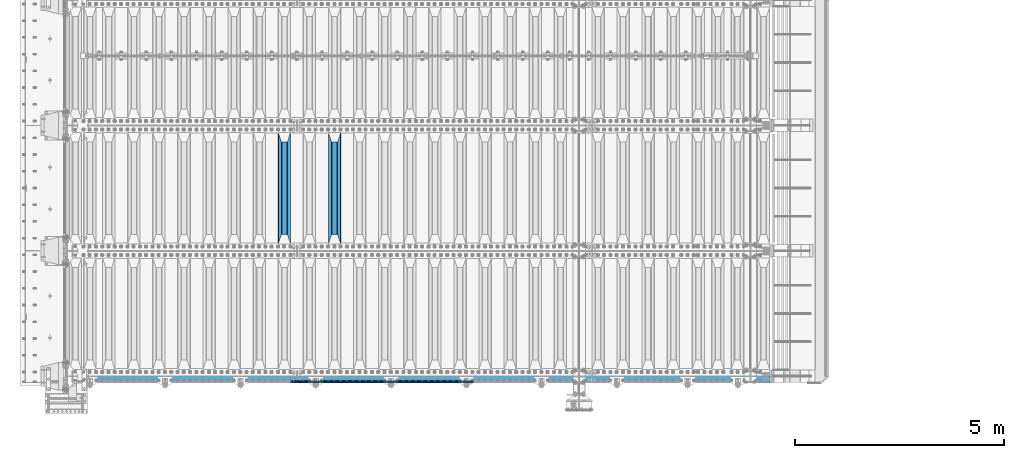
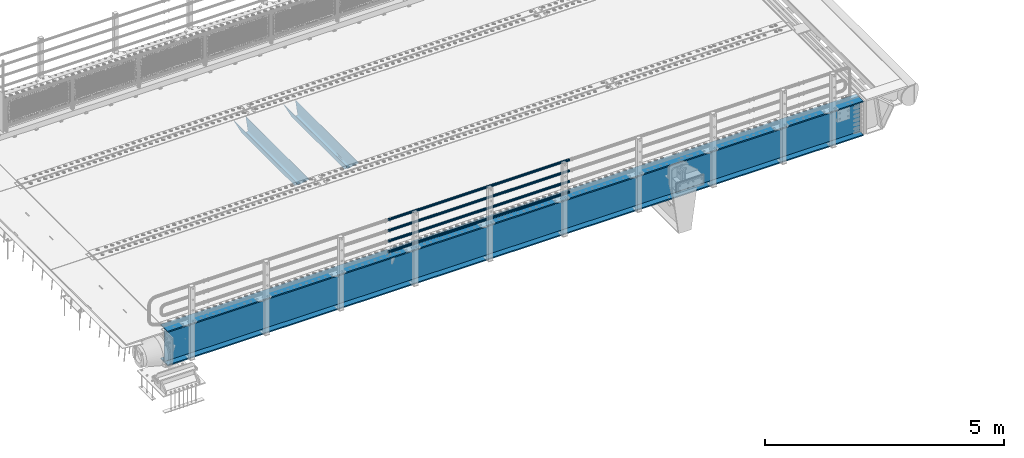
# One storey, part 112 of 247: 7 beams.
"""IFC2X3 building model written with IfcOpenShell, lengths in millimetres."""

import ifcopenshell
import ifcopenshell.guid

model = None  # the IFC model being written
_history = None  # IfcOwnerHistory: only IFC2X3 demands one
_inside = {}  # id of a spatial element -> (the spatial element, [elements in it])
_under = {}  # id of a project, library or spatial element -> (it, [spatial elements below it])
_declared = {}  # id of a project -> (the project, [libraries it declares])
_typed = {}  # id of a type object -> (the type object, [elements of that type])
_made_of = {}  # id of a material, layer set ... -> (it, [elements and type objects made of it])


def new_model(schema):
    """Start an empty IFC model of exactly this schema.

    Asked for "IFC4X3", IfcOpenShell would pick the latest addendum, in which some entities
    have other attributes; the version numbers below select the first issue.
    IFC2X3 requires an IfcOwnerHistory on every rooted entity: one is made here for all.
    """
    global model, _history
    if schema == "IFC4X3":
        model = ifcopenshell.file(schema_version=(4, 3, 0, 0))
    else:
        model = ifcopenshell.file(schema=schema)
    _inside.clear()
    _under.clear()
    _declared.clear()
    _typed.clear()
    _made_of.clear()
    _history = None
    if model.schema == "IFC2X3":
        org = make("IfcOrganization", Name="unknown")
        user = make(
            "IfcPersonAndOrganization",
            ThePerson=make("IfcPerson", FamilyName="unknown"),
            TheOrganization=org,
        )
        app = make(
            "IfcApplication",
            ApplicationDeveloper=org,
            Version="unknown",
            ApplicationFullName="unknown",
            ApplicationIdentifier="unknown",
        )
        _history = make(
            "IfcOwnerHistory",
            OwningUser=user,
            OwningApplication=app,
            ChangeAction="ADDED",
            CreationDate=0,
        )
    return model


def make(cls, **values):
    """One entity of the class cls with the attributes given. An attribute that is None is left unset."""
    return model.create_entity(
        cls, **{name: value for name, value in values.items() if value is not None}
    )


def rooted(cls, **values):
    """An entity with a GlobalId (a new one), such as an element, a storey or a relation."""
    return make(cls, GlobalId=ifcopenshell.guid.new(), OwnerHistory=_history, **values)


def si_unit(unit_type, name, prefix=None):
    """IfcSIUnit, for example si_unit("LENGTHUNIT", "METRE", prefix="MILLI")."""
    return make("IfcSIUnit", UnitType=unit_type, Prefix=prefix, Name=name)


def assignment(units):
    """IfcUnitAssignment: the units of a project."""
    return None if units is None else make("IfcUnitAssignment", Units=units)


def point(xyz):
    """IfcCartesianPoint."""
    return None if xyz is None else make("IfcCartesianPoint", Coordinates=xyz)


def direction(xyz):
    """IfcDirection."""
    return None if xyz is None else make("IfcDirection", DirectionRatios=xyz)


def frame(location, z_axis=None, x_axis=None):
    """IfcAxis2Placement3D, a coordinate frame: its origin and axes. An axis left out is left unset."""
    return make(
        "IfcAxis2Placement3D",
        Location=point(location),
        Axis=direction(z_axis),
        RefDirection=direction(x_axis),
    )


def origin_with_axes():
    """The frame at (0, 0, 0) with the z axis (0, 0, 1) and the x axis (1, 0, 0) written out."""
    return frame((0.0, 0.0, 0.0), z_axis=(0.0, 0.0, 1.0), x_axis=(1.0, 0.0, 0.0))


def place(relative_to, where):
    """IfcLocalPlacement: puts the frame where relative to a parent placement (None: the world)."""
    return make(
        "IfcLocalPlacement", PlacementRelTo=relative_to, RelativePlacement=where
    )


def context(
    kind, dimensions, precision=None, world=None, true_north=None, identifier=None
):
    """IfcGeometricRepresentationContext, for example the 3D "Model" context."""
    return make(
        "IfcGeometricRepresentationContext",
        ContextIdentifier=identifier,
        ContextType=kind,
        CoordinateSpaceDimension=dimensions,
        Precision=precision,
        WorldCoordinateSystem=world,
        TrueNorth=true_north,
    )


def subcontext(parent, identifier, kind, view, scale=None):
    """IfcGeometricRepresentationSubContext, for example "Body" below "Model"."""
    return make(
        "IfcGeometricRepresentationSubContext",
        ContextIdentifier=identifier,
        ContextType=kind,
        ParentContext=parent,
        TargetScale=scale,
        TargetView=view,
    )


def project(units=None, contexts=None):
    """IfcProject with its units and contexts."""
    return rooted(
        "IfcProject",
        Name="project",
        RepresentationContexts=contexts,
        UnitsInContext=assignment(units),
    )


def spatial(cls, under=None, at=None, **own):
    """A site, building, storey or space (cls), placed at a placement, below another one or the project."""
    s = rooted(cls, ObjectPlacement=at, **own)
    if under is not None:
        _under.setdefault(under.id(), (under, []))[1].append(s)
    return s


def faces_of(points, faces, orient=None, outer=None):
    """IfcFace entities. A face is a list of loops; a loop is a list of indices into points, from 0.

    orient and outer hold one flag for each loop. By default every Orientation is true, the
    first loop of a face is its IfcFaceOuterBound and the others are IfcFaceBound.
    """
    made = []
    for i, loops in enumerate(faces):
        bounds = []
        for j, loop in enumerate(loops):
            is_outer = j == 0 if outer is None else outer[i][j]
            bounds.append(
                make(
                    "IfcFaceOuterBound" if is_outer else "IfcFaceBound",
                    Bound=make("IfcPolyLoop", Polygon=[points[k] for k in loop]),
                    Orientation=True if orient is None else orient[i][j],
                )
            )
        made.append(make("IfcFace", Bounds=bounds))
    return made


def faceted_brep(points, faces, orient=None, outer=None, voids=None):
    """IfcFacetedBrep: a solid bounded by flat faces; with voids (closed shells), ...WithVoids."""
    shared = [point(p) for p in points]
    hull = make("IfcClosedShell", CfsFaces=faces_of(shared, faces, orient, outer))
    if voids is None:
        return make("IfcFacetedBrep", Outer=hull)
    return make(
        "IfcFacetedBrepWithVoids",
        Outer=hull,
        Voids=[
            make(cls, CfsFaces=faces_of(shared, fs, o, b)) for cls, fs, o, b in voids
        ],
    )


def shape(context_of_items, identifier, shape_type, items):
    """IfcShapeRepresentation: the items that make up one representation, for example the "Body"."""
    return make(
        "IfcShapeRepresentation",
        ContextOfItems=context_of_items,
        RepresentationIdentifier=identifier,
        RepresentationType=shape_type,
        Items=items,
    )


def material(Name=None, Category=None):
    """IfcMaterial."""
    return make("IfcMaterial", Name=Name, Category=Category)


def made_of(thing, what):
    """Note that an element or type object is made of a material, layer set ...; save() writes the relation."""
    if what is not None:
        _made_of.setdefault(what.id(), (what, []))[1].append(thing)
    return thing


def type_object(cls, material=None, **own):
    """A type object (cls), such as IfcWallType, which elements share."""
    return made_of(rooted(cls, **own), material)


def element(
    cls,
    number,
    at=None,
    inside=None,
    cuts=None,
    type_object=None,
    material=None,
    context=None,
    identifier="Body",
    shape_type=None,
    held_by="IfcProductDefinitionShape",
    body=None,
    shapes=None,
    **own,
):
    """One element of the class cls, such as IfcWall. Its Tag is "e" and its number.

    at: its placement. inside: the storey or other place that contains it. cuts: it is an
    opening in that element (IfcRelVoidsElement). A single representation is given by context,
    identifier, shape_type and body (its items); several are given by shapes. held_by: the class
    of the entity that holds the representations. save() writes the other relations.
    """
    e = rooted(cls, Tag="e%d" % number, ObjectPlacement=at, **own)
    if body is not None:
        shapes = [shape(context, identifier, shape_type, body)]
    if shapes is not None:
        e.Representation = make(held_by, Representations=shapes)
    if inside is not None:
        _inside.setdefault(inside.id(), (inside, []))[1].append(e)
    if cuts is not None:
        rooted(
            "IfcRelVoidsElement", RelatingBuildingElement=cuts, RelatedOpeningElement=e
        )
    if type_object is not None:
        _typed.setdefault(type_object.id(), (type_object, []))[1].append(e)
    return made_of(e, material)


def aggregate(whole, parts):
    """IfcRelAggregates: a whole, such as a stair, and the parts it consists of."""
    return rooted("IfcRelAggregates", RelatingObject=whole, RelatedObjects=parts)


def save(model, path):
    """Write the relations noted so far, then the file.

    IfcRelAggregates (storeys below a building ...), IfcRelContainedInSpatialStructure (elements
    in a storey), IfcRelDefinesByType, IfcRelAssociatesMaterial and IfcRelDeclares: one each for
    every whole, place, type object, material and project.
    """
    for whole, parts in _under.values():
        aggregate(whole, parts)
    for where, things in _inside.values():
        rooted(
            "IfcRelContainedInSpatialStructure",
            RelatedElements=things,
            RelatingStructure=where,
        )
    for kind, things in _typed.values():
        rooted("IfcRelDefinesByType", RelatedObjects=things, RelatingType=kind)
    for what, things in _made_of.values():
        rooted("IfcRelAssociatesMaterial", RelatedObjects=things, RelatingMaterial=what)
    for by, libraries in _declared.values():
        rooted("IfcRelDeclares", RelatingContext=by, RelatedDefinitions=libraries)
    model.write(path)


model = new_model("IFC2X3")

# Units and contexts
model_context = context("Model", 3, precision=1e-05, world=origin_with_axes())
body_context = subcontext(model_context, "Body", "Model", "MODEL_VIEW")
ifc_project = project(units=[si_unit("LENGTHUNIT", "METRE", prefix="MILLI"), si_unit("AREAUNIT", "SQUARE_METRE"), si_unit("VOLUMEUNIT", "CUBIC_METRE"), si_unit("MASSUNIT", "GRAM", prefix="KILO"), si_unit("TIMEUNIT", "SECOND"), si_unit("PLANEANGLEUNIT", "RADIAN"), si_unit("SOLIDANGLEUNIT", "STERADIAN"), si_unit("THERMODYNAMICTEMPERATUREUNIT", "DEGREE_CELSIUS"), si_unit("LUMINOUSINTENSITYUNIT", "LUMEN")], contexts=[model_context])

# Site, building, storey
site_placement = place(None, origin_with_axes())
site = spatial("IfcSite", under=ifc_project, at=site_placement, CompositionType="ELEMENT")
building_placement = place(site_placement, origin_with_axes())
building = spatial("IfcBuilding", under=site, at=building_placement, Name="Standard", CompositionType="ELEMENT")
storey_placement = place(building_placement, origin_with_axes())
storey = spatial("IfcBuildingStorey", under=building, at=storey_placement, Name="Undefined", CompositionType="ELEMENT", Elevation=0.0)

# Beams
ifc_material_1 = material(Name="STEEL/S355N")
beam_type_1 = type_object("IfcBeamType", PredefinedType="NOTDEFINED")
beam_1_placement = place(storey_placement, frame((6400.0, 3175.0, -115.0), z_axis=(0.0, 0.0, 1.0), x_axis=(0.0, 1.0, 0.0)))
element("IfcBeam", 1, at=beam_1_placement, inside=storey, type_object=beam_type_1, material=ifc_material_1, context=body_context, shape_type="Brep", body=[
    faceted_brep([(0.0, 150.0, 115.0), (0.0, 143.689999999999, 115.0), (2650.00000000297, 143.689999999999, 115.0), (2650.00000000297, 150.0, 115.0), (2650.00000000297, 142.059565218402, 110.0000000031), (2650.00000000297, 148.369565218403, 110.0000000031), (2441.90079219208, -80.1103600731112, -98.0992078077845), (2437.7588105432, -77.5672621345584, -102.241189456673), (2434.06523489746, -74.4080125315522, -105.934765102404), (2430.91086095089, -70.710272125576, -109.089139048974), (2428.37322971128, -66.5649389910068, -111.626770288588), (2426.51472138054, -62.0739139532889, -113.485278619323), (2425.38102192091, -57.3475956567672, -114.618978078955), (2424.99999999987, -52.5021667386536, -115.0), (2424.99999999987, 52.5021667386536, -115.0), (2425.38102192091, 57.3475956567672, -114.618978078955), (2426.51472138054, 62.0739139532889, -113.485278619323), (2428.37322971128, 66.5649389910068, -111.626770288588), (2430.91086095089, 70.710272125576, -109.089139048974), (2434.06523489746, 74.4080125315522, -105.934765102404), (2437.7588105432, 77.5672621345584, -102.241189456673), (2441.90079219208, 80.1103600731112, -98.0992078077846), (2446.38936140511, 81.9747917625791, -93.6106385947584), (2448.24948500409, 76.2713538057251, -91.7505149957729), (2444.62967112262, 74.76777986261, -95.3703288772456), (2441.28936334126, 72.7168944282894, -98.710636658607), (2438.31067330438, 70.1691124903846, -101.689326695487), (2435.76682334747, 67.1870637758839, -104.233176652398), (2433.72034654133, 63.8440531834895, -106.279653458539), (2432.22154950041, 60.222258798236, -107.778450499454), (2431.30727574265, 56.4107117849089, -108.692724257221), (2430.99999999987, 52.5031078186876, -109.0), (2430.99999999987, -52.5031078186876, -109.0), (2431.30727574265, -56.4107117849089, -108.692724257221), (2432.22154950041, -60.222258798236, -107.778450499454), (2433.72034654133, -63.8440531834895, -106.279653458539), (2435.76682334747, -67.1870637758839, -104.233176652398), (2438.31067330438, -70.1691124903846, -101.689326695487), (2441.28936334126, -72.7168944282894, -98.7106366586071), (2444.62967112262, -74.76777986261, -95.3703288772457), (2448.24948500409, -76.2713538057251, -91.7505149957729), (2650.00000000297, -142.059565218402, 110.0000000031), (2650.00000000297, -148.369565218403, 110.0000000031), (2446.38936140511, -81.9747917625791, -93.6106385947584), (2650.00000000297, -143.689999999999, 115.0), (2650.00000000297, -150.0, 115.0), (0.0, -143.689999999999, 115.0), (0.0, -150.0, 115.0), (0.0, -148.369565218261, 110.000000002663), (203.610638597422, -81.9747917625791, -93.6106385947584), (208.099207810448, -80.1103600731112, -98.0992078077845), (212.241189459336, -77.5672621345584, -102.241189456673), (215.934765105068, -74.4080125315522, -105.934765102404), (219.089139051637, -70.710272125576, -109.089139048974), (221.626770291251, -66.5649389910068, -111.626770288588), (223.485278621985, -62.0739139532889, -113.485278619323), (224.618978081617, -57.3475956567672, -114.618978078955), (225.000000002663, -52.5021667386536, -115.0), (225.000000002663, 52.5021667386536, -115.0), (224.618978081617, 57.3475956567672, -114.618978078955), (223.485278621985, 62.0739139532889, -113.485278619323), (221.626770291251, 66.5649389910068, -111.626770288588), (219.089139051637, 70.710272125576, -109.089139048974), (215.934765105068, 74.4080125315522, -105.934765102404), (212.241189459336, 77.5672621345584, -102.241189456673), (208.099207810448, 80.1103600731112, -98.0992078077846), (203.610638597422, 81.9747917625791, -93.6106385947584), (0.0, 148.369565218261, 110.000000002663), (0.0, 142.05956521826, 110.000000002663), (201.750514998436, 76.2713538057251, -91.7505149957729), (205.370328879908, 74.76777986261, -95.3703288772456), (208.710636661271, 72.7168944282894, -98.710636658607), (211.68932669815, 70.1691124903846, -101.689326695487), (214.233176655061, 67.1870637758839, -104.233176652398), (216.279653461202, 63.8440531834895, -106.279653458539), (217.778450502117, 60.222258798236, -107.778450499454), (218.692724259885, 56.4107117849089, -108.692724257221), (219.000000002663, 52.5031078186876, -109.0), (219.000000002663, -52.5031078186876, -109.0), (218.692724259885, -56.4107117849089, -108.692724257221), (217.778450502117, -60.222258798236, -107.778450499454), (216.279653461202, -63.8440531834895, -106.279653458539), (214.233176655061, -67.1870637758839, -104.233176652398), (211.68932669815, -70.1691124903846, -101.689326695487), (208.710636661271, -72.7168944282894, -98.7106366586071), (205.370328879908, -74.76777986261, -95.3703288772457), (201.750514998436, -76.2713538057251, -91.7505149957729), (0.0, -142.05956521826, 110.000000002663)], [[[0, 1, 2, 3]], [[3, 2, 4, 5]], [[6, 7, 8, 9, 10, 11, 12, 13, 14, 15, 16, 17, 18, 19, 20, 21, 22, 5, 4, 23, 24, 25, 26, 27, 28, 29, 30, 31, 32, 33, 34, 35, 36, 37, 38, 39, 40, 41, 42, 43]], [[44, 45, 42, 41]], [[46, 47, 45, 44]], [[43, 42, 45, 47, 48, 49]], [[6, 43, 49, 50]], [[7, 6, 50, 51]], [[8, 7, 51, 52]], [[9, 8, 52, 53]], [[10, 9, 53, 54]], [[11, 10, 54, 55]], [[12, 11, 55, 56]], [[13, 12, 56, 57]], [[14, 13, 57, 58]], [[15, 14, 58, 59]], [[16, 15, 59, 60]], [[17, 16, 60, 61]], [[18, 17, 61, 62]], [[19, 18, 62, 63]], [[20, 19, 63, 64]], [[21, 20, 64, 65]], [[22, 21, 65, 66]], [[0, 3, 5, 22, 66, 67]], [[1, 0, 67, 68]], [[23, 4, 2, 1, 68, 69]], [[24, 23, 69, 70]], [[25, 24, 70, 71]], [[26, 25, 71, 72]], [[27, 26, 72, 73]], [[28, 27, 73, 74]], [[29, 28, 74, 75]], [[30, 29, 75, 76]], [[31, 30, 76, 77]], [[32, 31, 77, 78]], [[33, 32, 78, 79]], [[34, 33, 79, 80]], [[35, 34, 80, 81]], [[36, 35, 81, 82]], [[37, 36, 82, 83]], [[38, 37, 83, 84]], [[39, 38, 84, 85]], [[40, 39, 85, 86]], [[46, 44, 41, 40, 86, 87]], [[47, 46, 87, 48]], [[86, 85, 84, 83, 82, 81, 80, 79, 78, 77, 76, 75, 74, 73, 72, 71, 70, 69, 68, 67, 66, 65, 64, 63, 62, 61, 60, 59, 58, 57, 56, 55, 54, 53, 52, 51, 50, 49, 48, 87]]]),
])
beam_2_placement = place(storey_placement, frame((5200.0, 3175.0, -115.0), z_axis=(0.0, 0.0, 1.0), x_axis=(0.0, 1.0, 0.0)))
element("IfcBeam", 2, at=beam_2_placement, inside=storey, type_object=beam_type_1, material=ifc_material_1, context=body_context, shape_type="Brep", body=[
    faceted_brep([(0.0, 150.0, 115.0), (0.0, 143.689999999999, 115.0), (2650.00000000297, 143.689999999999, 115.0), (2650.00000000297, 150.0, 115.0), (2650.00000000297, 142.059565218402, 110.0000000031), (2650.00000000297, 148.369565218403, 110.0000000031), (2441.90079219208, -80.1103600731112, -98.0992078077845), (2437.7588105432, -77.5672621345584, -102.241189456673), (2434.06523489746, -74.4080125315522, -105.934765102404), (2430.91086095089, -70.710272125576, -109.089139048974), (2428.37322971128, -66.5649389910068, -111.626770288588), (2426.51472138054, -62.0739139532889, -113.485278619323), (2425.38102192091, -57.3475956567672, -114.618978078955), (2424.99999999987, -52.5021667386536, -115.0), (2424.99999999987, 52.5021667386536, -115.0), (2425.38102192091, 57.3475956567672, -114.618978078955), (2426.51472138054, 62.0739139532889, -113.485278619323), (2428.37322971128, 66.5649389910068, -111.626770288588), (2430.91086095089, 70.710272125576, -109.089139048974), (2434.06523489746, 74.4080125315522, -105.934765102404), (2437.7588105432, 77.5672621345584, -102.241189456673), (2441.90079219208, 80.1103600731112, -98.0992078077846), (2446.38936140511, 81.9747917625791, -93.6106385947584), (2448.24948500409, 76.2713538057251, -91.7505149957729), (2444.62967112262, 74.76777986261, -95.3703288772456), (2441.28936334126, 72.7168944282894, -98.710636658607), (2438.31067330438, 70.1691124903846, -101.689326695487), (2435.76682334747, 67.1870637758839, -104.233176652398), (2433.72034654133, 63.8440531834895, -106.279653458539), (2432.22154950041, 60.222258798236, -107.778450499454), (2431.30727574265, 56.4107117849089, -108.692724257221), (2430.99999999987, 52.5031078186876, -109.0), (2430.99999999987, -52.5031078186876, -109.0), (2431.30727574265, -56.4107117849089, -108.692724257221), (2432.22154950041, -60.222258798236, -107.778450499454), (2433.72034654133, -63.8440531834895, -106.279653458539), (2435.76682334747, -67.1870637758839, -104.233176652398), (2438.31067330438, -70.1691124903846, -101.689326695487), (2441.28936334126, -72.7168944282894, -98.7106366586071), (2444.62967112262, -74.76777986261, -95.3703288772457), (2448.24948500409, -76.2713538057251, -91.7505149957729), (2650.00000000297, -142.059565218402, 110.0000000031), (2650.00000000297, -148.369565218403, 110.0000000031), (2446.38936140511, -81.9747917625791, -93.6106385947584), (2650.00000000297, -143.689999999999, 115.0), (2650.00000000297, -150.0, 115.0), (0.0, -143.689999999999, 115.0), (0.0, -150.0, 115.0), (0.0, -148.369565218261, 110.000000002663), (203.610638597422, -81.9747917625791, -93.6106385947584), (208.099207810448, -80.1103600731112, -98.0992078077845), (212.241189459336, -77.5672621345584, -102.241189456673), (215.934765105068, -74.4080125315522, -105.934765102404), (219.089139051637, -70.710272125576, -109.089139048974), (221.626770291251, -66.5649389910068, -111.626770288588), (223.485278621985, -62.0739139532889, -113.485278619323), (224.618978081617, -57.3475956567672, -114.618978078955), (225.000000002663, -52.5021667386536, -115.0), (225.000000002663, 52.5021667386536, -115.0), (224.618978081617, 57.3475956567672, -114.618978078955), (223.485278621985, 62.0739139532889, -113.485278619323), (221.626770291251, 66.5649389910068, -111.626770288588), (219.089139051637, 70.710272125576, -109.089139048974), (215.934765105068, 74.4080125315522, -105.934765102404), (212.241189459336, 77.5672621345584, -102.241189456673), (208.099207810448, 80.1103600731112, -98.0992078077846), (203.610638597422, 81.9747917625791, -93.6106385947584), (0.0, 148.369565218261, 110.000000002663), (0.0, 142.05956521826, 110.000000002663), (201.750514998436, 76.2713538057251, -91.7505149957729), (205.370328879908, 74.76777986261, -95.3703288772456), (208.710636661271, 72.7168944282894, -98.710636658607), (211.68932669815, 70.1691124903846, -101.689326695487), (214.233176655061, 67.1870637758839, -104.233176652398), (216.279653461202, 63.8440531834895, -106.279653458539), (217.778450502117, 60.222258798236, -107.778450499454), (218.692724259885, 56.4107117849089, -108.692724257221), (219.000000002663, 52.5031078186876, -109.0), (219.000000002663, -52.5031078186876, -109.0), (218.692724259885, -56.4107117849089, -108.692724257221), (217.778450502117, -60.222258798236, -107.778450499454), (216.279653461202, -63.8440531834895, -106.279653458539), (214.233176655061, -67.1870637758839, -104.233176652398), (211.68932669815, -70.1691124903846, -101.689326695487), (208.710636661271, -72.7168944282894, -98.7106366586071), (205.370328879908, -74.76777986261, -95.3703288772457), (201.750514998436, -76.2713538057251, -91.7505149957729), (0.0, -142.05956521826, 110.000000002663)], [[[0, 1, 2, 3]], [[3, 2, 4, 5]], [[6, 7, 8, 9, 10, 11, 12, 13, 14, 15, 16, 17, 18, 19, 20, 21, 22, 5, 4, 23, 24, 25, 26, 27, 28, 29, 30, 31, 32, 33, 34, 35, 36, 37, 38, 39, 40, 41, 42, 43]], [[44, 45, 42, 41]], [[46, 47, 45, 44]], [[43, 42, 45, 47, 48, 49]], [[6, 43, 49, 50]], [[7, 6, 50, 51]], [[8, 7, 51, 52]], [[9, 8, 52, 53]], [[10, 9, 53, 54]], [[11, 10, 54, 55]], [[12, 11, 55, 56]], [[13, 12, 56, 57]], [[14, 13, 57, 58]], [[15, 14, 58, 59]], [[16, 15, 59, 60]], [[17, 16, 60, 61]], [[18, 17, 61, 62]], [[19, 18, 62, 63]], [[20, 19, 63, 64]], [[21, 20, 64, 65]], [[22, 21, 65, 66]], [[0, 3, 5, 22, 66, 67]], [[1, 0, 67, 68]], [[23, 4, 2, 1, 68, 69]], [[24, 23, 69, 70]], [[25, 24, 70, 71]], [[26, 25, 71, 72]], [[27, 26, 72, 73]], [[28, 27, 73, 74]], [[29, 28, 74, 75]], [[30, 29, 75, 76]], [[31, 30, 76, 77]], [[32, 31, 77, 78]], [[33, 32, 78, 79]], [[34, 33, 79, 80]], [[35, 34, 80, 81]], [[36, 35, 81, 82]], [[37, 36, 82, 83]], [[38, 37, 83, 84]], [[39, 38, 84, 85]], [[40, 39, 85, 86]], [[46, 44, 41, 40, 86, 87]], [[47, 46, 87, 48]], [[86, 85, 84, 83, 82, 81, 80, 79, 78, 77, 76, 75, 74, 73, 72, 71, 70, 69, 68, 67, 66, 65, 64, 63, 62, 61, 60, 59, 58, 57, 56, 55, 54, 53, 52, 51, 50, 49, 48, 87]]]),
])
ifc_material_2 = material()
beam_type_2 = type_object("IfcBeamType", PredefinedType="NOTDEFINED")
beam_3_placement = place(storey_placement, frame((9727.99999999987, -129.849999999907, 149.849999999725), z_axis=(0.0, 0.0, -1.0), x_axis=(-1.0, 0.0, 0.0)))
element("IfcBeam", 3, at=beam_3_placement, inside=storey, type_object=beam_type_2, material=ifc_material_2, context=body_context, shape_type="Brep", body=[
    faceted_brep([(0.0, -26.5499999999993, 0.0), (0.0, -24.5290015881747, 10.1602451292931), (4384.00249699992, -24.5290015881747, 10.1602451292931), (4384.00249699992, -26.5499999999993, 0.0), (0.0, -18.7736850405036, 18.7736850405028), (4384.00249699992, -18.7736850405036, 18.7736850405028), (0.0, -10.1602451292929, 24.5290015881747), (4384.00249699992, -10.1602451292929, 24.5290015881747), (0.0, 0.0, 26.55), (4384.00249699992, 0.0, 26.55), (0.0, 10.1602451292929, 24.5290015881747), (4384.00249699992, 10.1602451292929, 24.5290015881747), (0.0, 18.7736850405036, 18.7736850405028), (4384.00249699992, 18.7736850405036, 18.7736850405028), (0.0, 24.5290015881747, 10.1602451292931), (4384.00249699992, 24.5290015881747, 10.1602451292931), (0.0, 26.5499999999993, 0.0), (4384.00249699992, 26.5499999999993, 0.0), (0.0, 24.5290015881747, -10.1602451292931), (4384.00249699992, 24.5290015881747, -10.1602451292931), (0.0, 18.7736850405036, -18.7736850405028), (4384.00249699992, 18.7736850405036, -18.7736850405028), (0.0, 10.1602451292929, -24.5290015881747), (4384.00249699992, 10.1602451292929, -24.5290015881747), (0.0, 0.0, -26.55), (4384.00249699992, 0.0, -26.55), (0.0, -10.1602451292929, -24.5290015881747), (4384.00249699992, -10.1602451292929, -24.5290015881747), (0.0, -18.7736850405036, -18.7736850405028), (4384.00249699992, -18.7736850405036, -18.7736850405028), (0.0, -24.5290015881747, -10.1602451292931), (4384.00249699992, -24.5290015881747, -10.1602451292931), (0.0, -30.1499999999996, 0.0), (0.0, -27.8549679052148, -11.5379054858076), (4384.00249699992, -27.8549679052157, -11.5379054858075), (4384.00249699992, -30.1499999999996, 0.0), (0.0, -21.3192694527743, -21.3192694527752), (4384.00249699992, -21.3192694527752, -21.3192694527744), (0.0, -11.5379054858076, -27.8549679052157), (4384.00249699992, -11.5379054858076, -27.8549679052153), (0.0, 0.0, -30.1499999999996), (4384.00249699992, 0.0, -30.15), (0.0, 11.5379054858076, -27.8549679052157), (4384.00249699992, 11.5379054858076, -27.8549679052153), (0.0, 21.3192694527743, -21.3192694527752), (4384.00249699992, 21.3192694527752, -21.3192694527744), (0.0, 27.8549679052157, -11.5379054858076), (4384.00249699992, 27.8549679052157, -11.5379054858074), (0.0, 30.1499999999996, 0.0), (4384.00249699992, 30.1499999999996, 0.0), (0.0, 27.8549679052157, 11.5379054858076), (4384.00249699992, 27.8549679052157, 11.5379054858075), (0.0, 21.3192694527743, 21.3192694527752), (4384.00249699992, 21.3192694527752, 21.3192694527744), (0.0, 11.5379054858076, 27.8549679052157), (4384.00249699992, 11.5379054858076, 27.8549679052153), (0.0, 0.0, 30.1499999999996), (4384.00249699992, 0.0, 30.15), (0.0, -11.5379054858076, 27.8549679052157), (4384.00249699992, -11.5379054858076, 27.8549679052153), (0.0, -21.3192694527743, 21.3192694527752), (4384.00249699992, -21.3192694527752, 21.3192694527744), (0.0, -27.8549679052157, 11.5379054858076), (4384.00249699992, -27.8549679052157, 11.5379054858075)], [[[0, 1, 2, 3]], [[1, 4, 5, 2]], [[4, 6, 7, 5]], [[6, 8, 9, 7]], [[8, 10, 11, 9]], [[10, 12, 13, 11]], [[12, 14, 15, 13]], [[14, 16, 17, 15]], [[16, 18, 19, 17]], [[18, 20, 21, 19]], [[20, 22, 23, 21]], [[22, 24, 25, 23]], [[24, 26, 27, 25]], [[26, 28, 29, 27]], [[28, 30, 31, 29]], [[30, 0, 3, 31]], [[32, 33, 34, 35]], [[33, 36, 37, 34]], [[36, 38, 39, 37]], [[38, 40, 41, 39]], [[40, 42, 43, 41]], [[42, 44, 45, 43]], [[44, 46, 47, 45]], [[46, 48, 49, 47]], [[48, 50, 51, 49]], [[50, 52, 53, 51]], [[52, 54, 55, 53]], [[54, 56, 57, 55]], [[56, 58, 59, 57]], [[58, 60, 61, 59]], [[60, 62, 63, 61]], [[62, 32, 35, 63]], [[37, 39, 41, 43, 45, 47, 49, 51, 53, 55, 57, 59, 61, 63, 35, 34], [5, 7, 9, 11, 13, 15, 17, 19, 21, 23, 25, 27, 29, 31, 3, 2]], [[62, 60, 58, 56, 54, 52, 50, 48, 46, 44, 42, 40, 38, 36, 33, 32], [30, 28, 26, 24, 22, 20, 18, 16, 14, 12, 10, 8, 6, 4, 1, 0]]]),
])
beam_4_placement = place(storey_placement, frame((9727.99999999987, -129.849999999907, 420.149999999728), z_axis=(0.0, 0.0, -1.0), x_axis=(-1.0, 0.0, 0.0)))
element("IfcBeam", 4, at=beam_4_placement, inside=storey, type_object=beam_type_2, material=ifc_material_2, context=body_context, shape_type="Brep", body=[
    faceted_brep([(0.0, -26.5499999999993, 0.0), (0.0, -24.5290015881747, 10.1602451292931), (4384.00249699992, -24.5290015881747, 10.1602451292931), (4384.00249699992, -26.5499999999993, 0.0), (0.0, -18.7736850405036, 18.7736850405028), (4384.00249699992, -18.7736850405036, 18.7736850405028), (0.0, -10.1602451292929, 24.5290015881747), (4384.00249699992, -10.1602451292929, 24.5290015881747), (0.0, 0.0, 26.55), (4384.00249699992, 0.0, 26.55), (0.0, 10.1602451292929, 24.5290015881747), (4384.00249699992, 10.1602451292929, 24.5290015881747), (0.0, 18.7736850405036, 18.7736850405028), (4384.00249699992, 18.7736850405036, 18.7736850405028), (0.0, 24.5290015881747, 10.1602451292931), (4384.00249699992, 24.5290015881747, 10.1602451292931), (0.0, 26.5499999999993, 0.0), (4384.00249699992, 26.5499999999993, 0.0), (0.0, 24.5290015881747, -10.1602451292931), (4384.00249699992, 24.5290015881747, -10.1602451292931), (0.0, 18.7736850405036, -18.7736850405028), (4384.00249699992, 18.7736850405036, -18.7736850405028), (0.0, 10.1602451292929, -24.5290015881747), (4384.00249699992, 10.1602451292929, -24.5290015881747), (0.0, 0.0, -26.55), (4384.00249699992, 0.0, -26.55), (0.0, -10.1602451292929, -24.5290015881747), (4384.00249699992, -10.1602451292929, -24.5290015881747), (0.0, -18.7736850405036, -18.7736850405028), (4384.00249699992, -18.7736850405036, -18.7736850405028), (0.0, -24.5290015881747, -10.1602451292931), (4384.00249699992, -24.5290015881747, -10.1602451292931), (0.0, -30.1499999999996, 0.0), (0.0, -27.8549679052148, -11.5379054858076), (4384.00249699992, -27.8549679052157, -11.5379054858075), (4384.00249699992, -30.1499999999996, 0.0), (0.0, -21.3192694527743, -21.3192694527752), (4384.00249699992, -21.3192694527752, -21.3192694527744), (0.0, -11.5379054858076, -27.8549679052157), (4384.00249699992, -11.5379054858076, -27.8549679052153), (0.0, 0.0, -30.1499999999996), (4384.00249699992, 0.0, -30.15), (0.0, 11.5379054858076, -27.8549679052157), (4384.00249699992, 11.5379054858076, -27.8549679052153), (0.0, 21.3192694527743, -21.3192694527752), (4384.00249699992, 21.3192694527752, -21.3192694527744), (0.0, 27.8549679052157, -11.5379054858076), (4384.00249699992, 27.8549679052157, -11.5379054858074), (0.0, 30.1499999999996, 0.0), (4384.00249699992, 30.1499999999996, 0.0), (0.0, 27.8549679052157, 11.5379054858076), (4384.00249699992, 27.8549679052157, 11.5379054858075), (0.0, 21.3192694527743, 21.3192694527752), (4384.00249699992, 21.3192694527752, 21.3192694527744), (0.0, 11.5379054858076, 27.8549679052157), (4384.00249699992, 11.5379054858076, 27.8549679052153), (0.0, 0.0, 30.1499999999996), (4384.00249699992, 0.0, 30.15), (0.0, -11.5379054858076, 27.8549679052157), (4384.00249699992, -11.5379054858076, 27.8549679052153), (0.0, -21.3192694527743, 21.3192694527752), (4384.00249699992, -21.3192694527752, 21.3192694527744), (0.0, -27.8549679052157, 11.5379054858076), (4384.00249699992, -27.8549679052157, 11.5379054858075)], [[[0, 1, 2, 3]], [[1, 4, 5, 2]], [[4, 6, 7, 5]], [[6, 8, 9, 7]], [[8, 10, 11, 9]], [[10, 12, 13, 11]], [[12, 14, 15, 13]], [[14, 16, 17, 15]], [[16, 18, 19, 17]], [[18, 20, 21, 19]], [[20, 22, 23, 21]], [[22, 24, 25, 23]], [[24, 26, 27, 25]], [[26, 28, 29, 27]], [[28, 30, 31, 29]], [[30, 0, 3, 31]], [[32, 33, 34, 35]], [[33, 36, 37, 34]], [[36, 38, 39, 37]], [[38, 40, 41, 39]], [[40, 42, 43, 41]], [[42, 44, 45, 43]], [[44, 46, 47, 45]], [[46, 48, 49, 47]], [[48, 50, 51, 49]], [[50, 52, 53, 51]], [[52, 54, 55, 53]], [[54, 56, 57, 55]], [[56, 58, 59, 57]], [[58, 60, 61, 59]], [[60, 62, 63, 61]], [[62, 32, 35, 63]], [[37, 39, 41, 43, 45, 47, 49, 51, 53, 55, 57, 59, 61, 63, 35, 34], [5, 7, 9, 11, 13, 15, 17, 19, 21, 23, 25, 27, 29, 31, 3, 2]], [[62, 60, 58, 56, 54, 52, 50, 48, 46, 44, 42, 40, 38, 36, 33, 32], [30, 28, 26, 24, 22, 20, 18, 16, 14, 12, 10, 8, 6, 4, 1, 0]]]),
])
beam_5_placement = place(storey_placement, frame((9727.99999999987, -129.849999999907, 969.849999999725), z_axis=(0.0, 0.0, -1.0), x_axis=(-1.0, 0.0, 0.0)))
element("IfcBeam", 5, at=beam_5_placement, inside=storey, type_object=beam_type_2, material=ifc_material_2, context=body_context, shape_type="Brep", body=[
    faceted_brep([(0.0, -26.5499999999993, 0.0), (0.0, -24.5290015881747, 10.1602451292931), (4384.00249699992, -24.5290015881747, 10.1602451292931), (4384.00249699992, -26.5499999999993, 0.0), (0.0, -18.7736850405036, 18.7736850405028), (4384.00249699992, -18.7736850405036, 18.7736850405028), (0.0, -10.1602451292929, 24.5290015881747), (4384.00249699992, -10.1602451292929, 24.5290015881747), (0.0, 0.0, 26.55), (4384.00249699992, 0.0, 26.55), (0.0, 10.1602451292929, 24.5290015881747), (4384.00249699992, 10.1602451292929, 24.5290015881747), (0.0, 18.7736850405036, 18.7736850405028), (4384.00249699992, 18.7736850405036, 18.7736850405028), (0.0, 24.5290015881747, 10.1602451292931), (4384.00249699992, 24.5290015881747, 10.1602451292931), (0.0, 26.5499999999993, 0.0), (4384.00249699992, 26.5499999999993, 0.0), (0.0, 24.5290015881747, -10.1602451292931), (4384.00249699992, 24.5290015881747, -10.1602451292931), (0.0, 18.7736850405036, -18.7736850405028), (4384.00249699992, 18.7736850405036, -18.7736850405028), (0.0, 10.1602451292929, -24.5290015881747), (4384.00249699992, 10.1602451292929, -24.5290015881747), (0.0, 0.0, -26.55), (4384.00249699992, 0.0, -26.55), (0.0, -10.1602451292929, -24.5290015881747), (4384.00249699992, -10.1602451292929, -24.5290015881747), (0.0, -18.7736850405036, -18.7736850405028), (4384.00249699992, -18.7736850405036, -18.7736850405028), (0.0, -24.5290015881747, -10.1602451292931), (4384.00249699992, -24.5290015881747, -10.1602451292931), (0.0, -30.1499999999996, 0.0), (0.0, -27.8549679052148, -11.5379054858076), (4384.00249699992, -27.8549679052157, -11.5379054858075), (4384.00249699992, -30.1499999999996, 0.0), (0.0, -21.3192694527743, -21.3192694527752), (4384.00249699992, -21.3192694527752, -21.3192694527744), (0.0, -11.5379054858076, -27.8549679052157), (4384.00249699992, -11.5379054858076, -27.8549679052153), (0.0, 0.0, -30.1499999999996), (4384.00249699992, 0.0, -30.15), (0.0, 11.5379054858076, -27.8549679052157), (4384.00249699992, 11.5379054858076, -27.8549679052153), (0.0, 21.3192694527743, -21.3192694527752), (4384.00249699992, 21.3192694527752, -21.3192694527744), (0.0, 27.8549679052157, -11.5379054858076), (4384.00249699992, 27.8549679052157, -11.5379054858074), (0.0, 30.1499999999996, 0.0), (4384.00249699992, 30.1499999999996, 0.0), (0.0, 27.8549679052157, 11.5379054858076), (4384.00249699992, 27.8549679052157, 11.5379054858075), (0.0, 21.3192694527743, 21.3192694527752), (4384.00249699992, 21.3192694527752, 21.3192694527744), (0.0, 11.5379054858076, 27.8549679052157), (4384.00249699992, 11.5379054858076, 27.8549679052153), (0.0, 0.0, 30.1499999999996), (4384.00249699992, 0.0, 30.15), (0.0, -11.5379054858076, 27.8549679052157), (4384.00249699992, -11.5379054858076, 27.8549679052153), (0.0, -21.3192694527743, 21.3192694527752), (4384.00249699992, -21.3192694527752, 21.3192694527744), (0.0, -27.8549679052157, 11.5379054858076), (4384.00249699992, -27.8549679052157, 11.5379054858075)], [[[0, 1, 2, 3]], [[1, 4, 5, 2]], [[4, 6, 7, 5]], [[6, 8, 9, 7]], [[8, 10, 11, 9]], [[10, 12, 13, 11]], [[12, 14, 15, 13]], [[14, 16, 17, 15]], [[16, 18, 19, 17]], [[18, 20, 21, 19]], [[20, 22, 23, 21]], [[22, 24, 25, 23]], [[24, 26, 27, 25]], [[26, 28, 29, 27]], [[28, 30, 31, 29]], [[30, 0, 3, 31]], [[32, 33, 34, 35]], [[33, 36, 37, 34]], [[36, 38, 39, 37]], [[38, 40, 41, 39]], [[40, 42, 43, 41]], [[42, 44, 45, 43]], [[44, 46, 47, 45]], [[46, 48, 49, 47]], [[48, 50, 51, 49]], [[50, 52, 53, 51]], [[52, 54, 55, 53]], [[54, 56, 57, 55]], [[56, 58, 59, 57]], [[58, 60, 61, 59]], [[60, 62, 63, 61]], [[62, 32, 35, 63]], [[37, 39, 41, 43, 45, 47, 49, 51, 53, 55, 57, 59, 61, 63, 35, 34], [5, 7, 9, 11, 13, 15, 17, 19, 21, 23, 25, 27, 29, 31, 3, 2]], [[62, 60, 58, 56, 54, 52, 50, 48, 46, 44, 42, 40, 38, 36, 33, 32], [30, 28, 26, 24, 22, 20, 18, 16, 14, 12, 10, 8, 6, 4, 1, 0]]]),
])
beam_6_placement = place(storey_placement, frame((9727.99999999987, -129.849999999907, 689.849999999725), z_axis=(0.0, 0.0, -1.0), x_axis=(-1.0, 0.0, 0.0)))
element("IfcBeam", 6, at=beam_6_placement, inside=storey, type_object=beam_type_2, material=ifc_material_2, context=body_context, shape_type="Brep", body=[
    faceted_brep([(0.0, -26.5499999999993, 0.0), (0.0, -24.5290015881747, 10.1602451292931), (4384.00249699992, -24.5290015881747, 10.1602451292931), (4384.00249699992, -26.5499999999993, 0.0), (0.0, -18.7736850405036, 18.7736850405028), (4384.00249699992, -18.7736850405036, 18.7736850405028), (0.0, -10.1602451292929, 24.5290015881747), (4384.00249699992, -10.1602451292929, 24.5290015881747), (0.0, 0.0, 26.55), (4384.00249699992, 0.0, 26.55), (0.0, 10.1602451292929, 24.5290015881747), (4384.00249699992, 10.1602451292929, 24.5290015881747), (0.0, 18.7736850405036, 18.7736850405028), (4384.00249699992, 18.7736850405036, 18.7736850405028), (0.0, 24.5290015881747, 10.1602451292931), (4384.00249699992, 24.5290015881747, 10.1602451292931), (0.0, 26.5499999999993, 0.0), (4384.00249699992, 26.5499999999993, 0.0), (0.0, 24.5290015881747, -10.1602451292931), (4384.00249699992, 24.5290015881747, -10.1602451292931), (0.0, 18.7736850405036, -18.7736850405028), (4384.00249699992, 18.7736850405036, -18.7736850405028), (0.0, 10.1602451292929, -24.5290015881747), (4384.00249699992, 10.1602451292929, -24.5290015881747), (0.0, 0.0, -26.55), (4384.00249699992, 0.0, -26.55), (0.0, -10.1602451292929, -24.5290015881747), (4384.00249699992, -10.1602451292929, -24.5290015881747), (0.0, -18.7736850405036, -18.7736850405028), (4384.00249699992, -18.7736850405036, -18.7736850405028), (0.0, -24.5290015881747, -10.1602451292931), (4384.00249699992, -24.5290015881747, -10.1602451292931), (0.0, -30.1499999999996, 0.0), (0.0, -27.8549679052148, -11.5379054858076), (4384.00249699992, -27.8549679052157, -11.5379054858075), (4384.00249699992, -30.1499999999996, 0.0), (0.0, -21.3192694527743, -21.3192694527752), (4384.00249699992, -21.3192694527752, -21.3192694527744), (0.0, -11.5379054858076, -27.8549679052157), (4384.00249699992, -11.5379054858076, -27.8549679052153), (0.0, 0.0, -30.1499999999996), (4384.00249699992, 0.0, -30.15), (0.0, 11.5379054858076, -27.8549679052157), (4384.00249699992, 11.5379054858076, -27.8549679052153), (0.0, 21.3192694527743, -21.3192694527752), (4384.00249699992, 21.3192694527752, -21.3192694527744), (0.0, 27.8549679052157, -11.5379054858076), (4384.00249699992, 27.8549679052157, -11.5379054858074), (0.0, 30.1499999999996, 0.0), (4384.00249699992, 30.1499999999996, 0.0), (0.0, 27.8549679052157, 11.5379054858076), (4384.00249699992, 27.8549679052157, 11.5379054858075), (0.0, 21.3192694527743, 21.3192694527752), (4384.00249699992, 21.3192694527752, 21.3192694527744), (0.0, 11.5379054858076, 27.8549679052157), (4384.00249699992, 11.5379054858076, 27.8549679052153), (0.0, 0.0, 30.1499999999996), (4384.00249699992, 0.0, 30.15), (0.0, -11.5379054858076, 27.8549679052157), (4384.00249699992, -11.5379054858076, 27.8549679052153), (0.0, -21.3192694527743, 21.3192694527752), (4384.00249699992, -21.3192694527752, 21.3192694527744), (0.0, -27.8549679052157, 11.5379054858076), (4384.00249699992, -27.8549679052157, 11.5379054858075)], [[[0, 1, 2, 3]], [[1, 4, 5, 2]], [[4, 6, 7, 5]], [[6, 8, 9, 7]], [[8, 10, 11, 9]], [[10, 12, 13, 11]], [[12, 14, 15, 13]], [[14, 16, 17, 15]], [[16, 18, 19, 17]], [[18, 20, 21, 19]], [[20, 22, 23, 21]], [[22, 24, 25, 23]], [[24, 26, 27, 25]], [[26, 28, 29, 27]], [[28, 30, 31, 29]], [[30, 0, 3, 31]], [[32, 33, 34, 35]], [[33, 36, 37, 34]], [[36, 38, 39, 37]], [[38, 40, 41, 39]], [[40, 42, 43, 41]], [[42, 44, 45, 43]], [[44, 46, 47, 45]], [[46, 48, 49, 47]], [[48, 50, 51, 49]], [[50, 52, 53, 51]], [[52, 54, 55, 53]], [[54, 56, 57, 55]], [[56, 58, 59, 57]], [[58, 60, 61, 59]], [[60, 62, 63, 61]], [[62, 32, 35, 63]], [[37, 39, 41, 43, 45, 47, 49, 51, 53, 55, 57, 59, 61, 63, 35, 34], [5, 7, 9, 11, 13, 15, 17, 19, 21, 23, 25, 27, 29, 31, 3, 2]], [[62, 60, 58, 56, 54, 52, 50, 48, 46, 44, 42, 40, 38, 36, 33, 32], [30, 28, 26, 24, 22, 20, 18, 16, 14, 12, 10, 8, 6, 4, 1, 0]]]),
])
beam_type_3 = type_object("IfcBeamType", Name="HEA900", PredefinedType="NOTDEFINED")
beam_7_placement = place(storey_placement, frame((10.0, 0.0, -445.0), z_axis=(0.0, 0.0, 1.0), x_axis=(1.0, 0.0, 0.0)))
element("IfcBeam", 7, at=beam_7_placement, inside=storey, type_object=beam_type_3, material=ifc_material_1, ObjectType="HEA900", context=body_context, shape_type="Brep", body=[
    faceted_brep([(0.0, 150.0, -445.0), (0.0, 150.0, -415.0), (16807.0, 150.0, -415.0), (16807.0, 150.0, -445.0), (0.0, 8.0, -415.0), (16807.0, 8.0, -415.0), (0.0, 8.0, 415.0), (16807.0, 8.0, 415.0), (0.0, 150.0, 415.0), (16807.0, 150.0, 415.0), (0.0, 150.0, 445.0), (16807.0, 150.0, 445.0), (0.0, -150.0, 445.0), (16807.0, -150.0, 445.0), (0.0, -150.0, 415.0), (16807.0, -150.0, 415.0), (0.0, -8.0, 415.0), (16807.0, -8.0, 415.0), (0.0, -8.0, -415.0), (16807.0, -8.0, -415.0), (0.0, -150.0, -415.0), (16807.0, -150.0, -415.0), (0.0, -150.0, -445.0), (16807.0, -150.0, -445.0)], [[[0, 1, 2, 3]], [[1, 4, 5, 2]], [[4, 6, 7, 5]], [[6, 8, 9, 7]], [[8, 10, 11, 9]], [[10, 12, 13, 11]], [[12, 14, 15, 13]], [[14, 16, 17, 15]], [[16, 18, 19, 17]], [[18, 20, 21, 19]], [[20, 22, 23, 21]], [[22, 0, 3, 23]], [[5, 7, 9, 11, 13, 15, 17, 19, 21, 23, 3, 2]], [[22, 20, 18, 16, 14, 12, 10, 8, 6, 4, 1, 0]]]),
])

save(model, "model.ifc")
